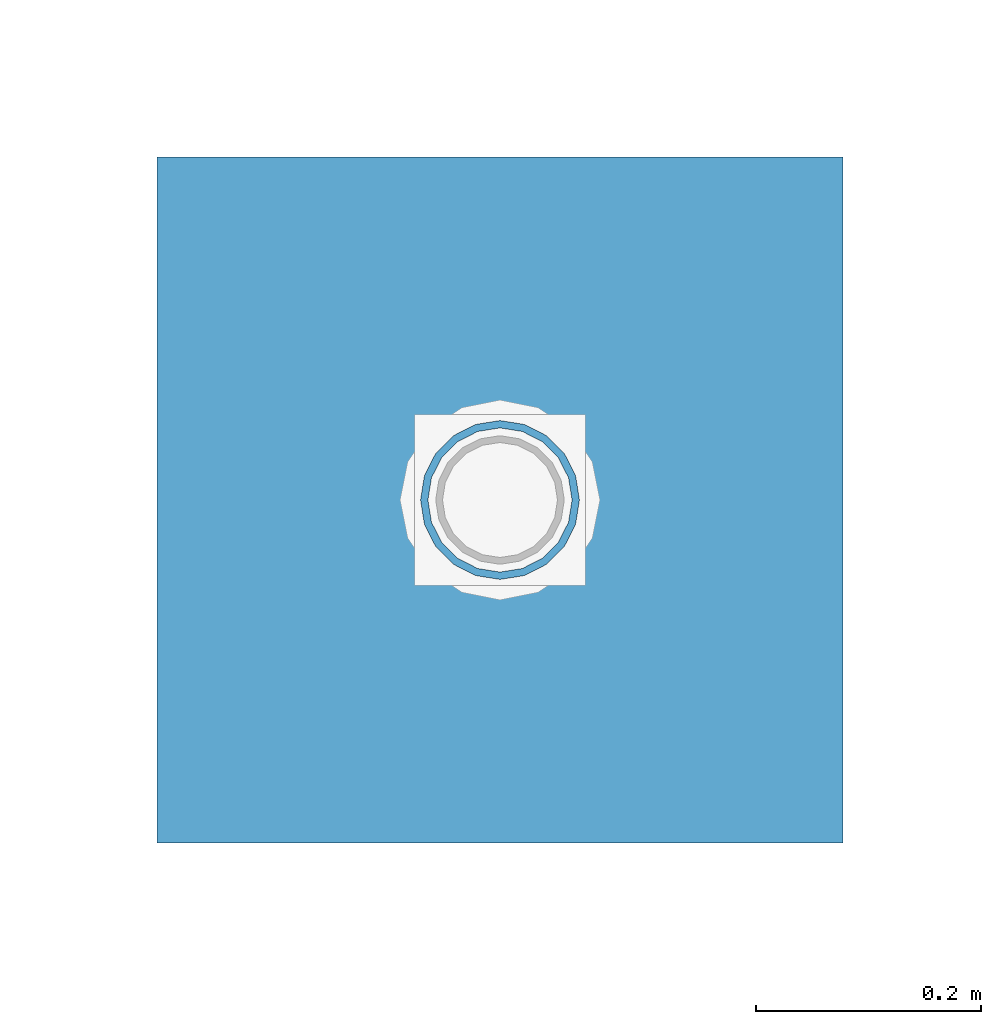
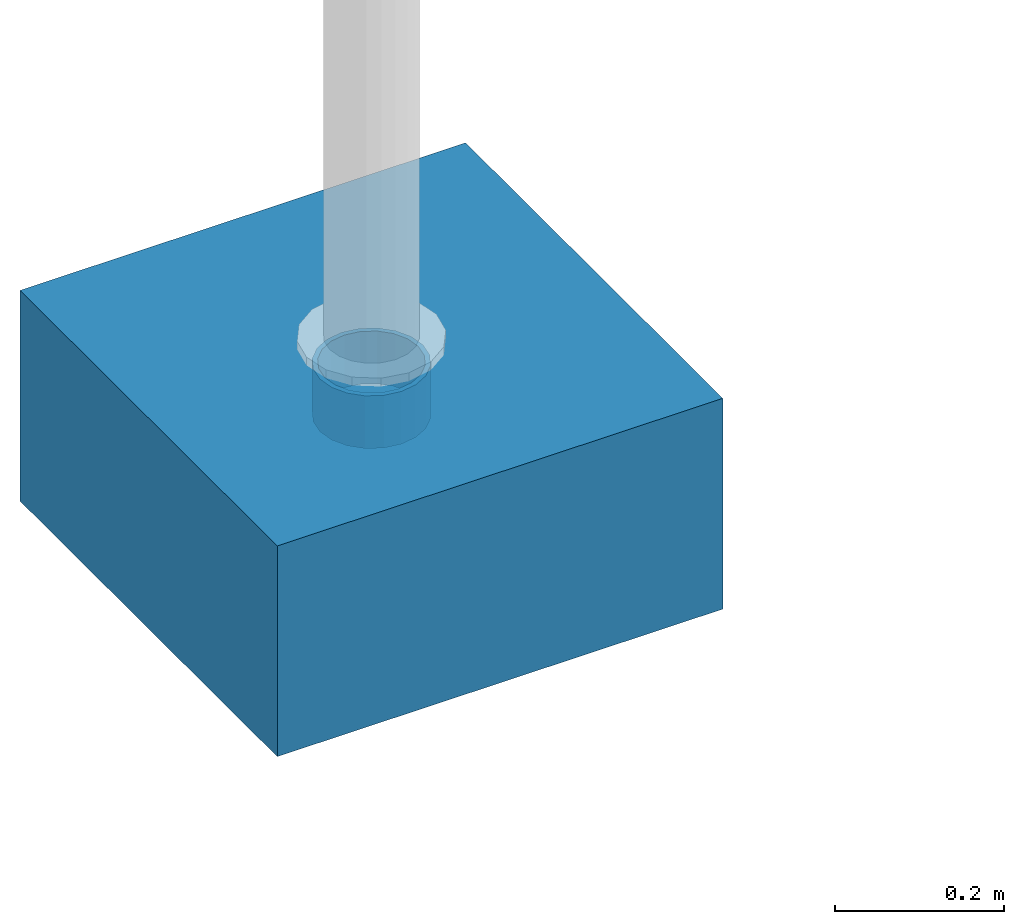
# One storey, part 1532 of 3843: 2 columns, 2 elements without a shape of their own.
"""IFC2X3 building model written with IfcOpenShell, lengths in millimetres."""

from ifc_helpers import new_model, si_unit, frame, origin_with_axes, place, context, subcontext, project, spatial, faceted_brep, material, type_object, element, aggregate, save


model = new_model("IFC2X3")

# Units and contexts
model_context = context("Model", 3, precision=1e-05, world=origin_with_axes())
body_context = subcontext(model_context, "Body", "Model", "MODEL_VIEW")
ifc_project = project(units=[si_unit("LENGTHUNIT", "METRE", prefix="MILLI"), si_unit("AREAUNIT", "SQUARE_METRE"), si_unit("VOLUMEUNIT", "CUBIC_METRE"), si_unit("MASSUNIT", "GRAM", prefix="KILO"), si_unit("TIMEUNIT", "SECOND"), si_unit("PLANEANGLEUNIT", "RADIAN"), si_unit("SOLIDANGLEUNIT", "STERADIAN"), si_unit("THERMODYNAMICTEMPERATUREUNIT", "DEGREE_CELSIUS"), si_unit("LUMINOUSINTENSITYUNIT", "LUMEN")], contexts=[model_context])

# Site, building, storey
site_placement = place(None, origin_with_axes())
site = spatial("IfcSite", under=ifc_project, at=site_placement, CompositionType="ELEMENT")
building_placement = place(site_placement, origin_with_axes())
building = spatial("IfcBuilding", under=site, at=building_placement, Name="Undefined", CompositionType="ELEMENT")
storey_placement = place(building_placement, origin_with_axes())
storey = spatial("IfcBuildingStorey", under=building, at=storey_placement, Name="Undefined", CompositionType="ELEMENT", Elevation=0.0)

# Assembly, column
assembly_1_placement = place(storey_placement, origin_with_axes())
assembly_1 = element("IfcElementAssembly", 1, at=assembly_1_placement, inside=storey, Name="PLATE", AssemblyPlace="NOTDEFINED", PredefinedType="RIGID_FRAME")
ifc_material_1 = material()
column_type_1 = type_object("IfcColumnType", Name="PIPE5SCH40", PredefinedType="NOTDEFINED")
column_1_placement = place(assembly_1_placement, frame((-31322.367188, 75641.398438, 30378.4), z_axis=(-1.0, 0.0, 0.0), x_axis=(0.0, 0.0, 1.0)))
column_1 = element("IfcColumn", 2, at=column_1_placement, type_object=column_type_1, material=ifc_material_1, Name="PIPE_SLEEVE", ObjectType="PIPE5SCH40", context=body_context, shape_type="Brep", body=[
    faceted_brep([(0.0, -64.0587999999998, 0.0), (0.0, -60.9235391660477, 19.7952578392724), (76.2000000000007, -60.9235391660477, 19.7952578392724), (76.2000000000007, -64.0587999999998, 0.0), (0.0, -51.8246578392655, 37.6528179195593), (76.2000000000007, -51.8246578392655, 37.6528179195593), (0.0, -37.6528179195529, 51.8246578392718), (76.2000000000007, -37.6528179195529, 51.8246578392718), (0.0, -19.795257839266, 60.9235391660477), (76.2000000000007, -19.795257839266, 60.9235391660477), (0.0, 0.0, 64.0587999999989), (76.2000000000007, 0.0, 64.0587999999989), (0.0, 19.795257839266, 60.9235391660477), (76.2000000000007, 19.795257839266, 60.9235391660477), (0.0, 37.6528179195529, 51.8246578392718), (76.2000000000007, 37.6528179195529, 51.8246578392718), (0.0, 51.8246578392655, 37.6528179195593), (76.2000000000007, 51.8246578392655, 37.6528179195593), (0.0, 60.9235391660477, 19.7952578392724), (76.2000000000007, 60.9235391660477, 19.7952578392724), (0.0, 64.0587999999998, 0.0), (76.2000000000007, 64.0587999999998, 0.0), (0.0, 60.9235391660477, -19.7952578392724), (76.2000000000007, 60.9235391660477, -19.7952578392724), (0.0, 51.8246578392655, -37.6528179195593), (76.2000000000007, 51.8246578392655, -37.6528179195593), (0.0, 37.6528179195529, -51.8246578392718), (76.2000000000007, 37.6528179195529, -51.8246578392718), (0.0, 19.795257839266, -60.9235391660477), (76.2000000000007, 19.795257839266, -60.9235391660477), (0.0, 0.0, -64.0587999999989), (76.2000000000007, 0.0, -64.0587999999989), (0.0, -19.795257839266, -60.9235391660477), (76.2000000000007, -19.795257839266, -60.9235391660477), (0.0, -37.6528179195529, -51.8246578392718), (76.2000000000007, -37.6528179195529, -51.8246578392718), (0.0, -51.8246578392655, -37.6528179195593), (76.2000000000007, -51.8246578392655, -37.6528179195593), (0.0, -60.9235391660477, -19.7952578392724), (76.2000000000007, -60.9235391660477, -19.7952578392724), (0.0, -70.6120000000001, 0.0), (0.0, -67.1560027286332, -21.8203080068051), (76.2000000000007, -67.1560027286332, -21.8203080068051), (76.2000000000007, -70.6120000000001, 0.0), (0.0, -57.1263080068038, -41.5046922348702), (76.2000000000007, -57.1263080068038, -41.5046922348702), (0.0, -41.5046922348765, -57.126308006802), (76.2000000000007, -41.5046922348765, -57.126308006802), (0.0, -21.8203080068042, -67.1560027286323), (76.2000000000007, -21.8203080068042, -67.1560027286323), (0.0, 0.0, -70.6119999999937), (76.2000000000007, 0.0, -70.6119999999937), (0.0, 21.8203080068042, -67.1560027286323), (76.2000000000007, 21.8203080068042, -67.1560027286323), (0.0, 41.5046922348765, -57.126308006802), (76.2000000000007, 41.5046922348765, -57.126308006802), (0.0, 57.1263080068038, -41.5046922348702), (76.2000000000007, 57.1263080068038, -41.5046922348702), (0.0, 67.1560027286332, -21.8203080068051), (76.2000000000007, 67.1560027286332, -21.8203080068051), (0.0, 70.6120000000001, 0.0), (76.2000000000007, 70.6120000000001, 0.0), (0.0, 67.1560027286332, 21.8203080068051), (76.2000000000007, 67.1560027286332, 21.8203080068051), (0.0, 57.1263080068038, 41.5046922348702), (76.2000000000007, 57.1263080068038, 41.5046922348702), (0.0, 41.5046922348765, 57.126308006802), (76.2000000000007, 41.5046922348765, 57.126308006802), (0.0, 21.8203080068042, 67.1560027286323), (76.2000000000007, 21.8203080068042, 67.1560027286323), (0.0, 0.0, 70.6119999999937), (76.2000000000007, 0.0, 70.6119999999937), (0.0, -21.8203080068042, 67.1560027286323), (76.2000000000007, -21.8203080068042, 67.1560027286323), (0.0, -41.5046922348765, 57.126308006802), (76.2000000000007, -41.5046922348765, 57.126308006802), (0.0, -57.1263080068038, 41.5046922348702), (76.2000000000007, -57.1263080068038, 41.5046922348702), (0.0, -67.1560027286332, 21.8203080068051), (76.2000000000007, -67.1560027286332, 21.8203080068051)], [[[0, 1, 2, 3]], [[1, 4, 5, 2]], [[4, 6, 7, 5]], [[6, 8, 9, 7]], [[8, 10, 11, 9]], [[10, 12, 13, 11]], [[12, 14, 15, 13]], [[14, 16, 17, 15]], [[16, 18, 19, 17]], [[18, 20, 21, 19]], [[20, 22, 23, 21]], [[22, 24, 25, 23]], [[24, 26, 27, 25]], [[26, 28, 29, 27]], [[28, 30, 31, 29]], [[30, 32, 33, 31]], [[32, 34, 35, 33]], [[34, 36, 37, 35]], [[36, 38, 39, 37]], [[38, 0, 3, 39]], [[40, 41, 42, 43]], [[41, 44, 45, 42]], [[44, 46, 47, 45]], [[46, 48, 49, 47]], [[48, 50, 51, 49]], [[50, 52, 53, 51]], [[52, 54, 55, 53]], [[54, 56, 57, 55]], [[56, 58, 59, 57]], [[58, 60, 61, 59]], [[60, 62, 63, 61]], [[62, 64, 65, 63]], [[64, 66, 67, 65]], [[66, 68, 69, 67]], [[68, 70, 71, 69]], [[70, 72, 73, 71]], [[72, 74, 75, 73]], [[74, 76, 77, 75]], [[76, 78, 79, 77]], [[78, 40, 43, 79]], [[45, 47, 49, 51, 53, 55, 57, 59, 61, 63, 65, 67, 69, 71, 73, 75, 77, 79, 43, 42], [5, 7, 9, 11, 13, 15, 17, 19, 21, 23, 25, 27, 29, 31, 33, 35, 37, 39, 3, 2]], [[78, 76, 74, 72, 70, 68, 66, 64, 62, 60, 58, 56, 54, 52, 50, 48, 46, 44, 41, 40], [38, 36, 34, 32, 30, 28, 26, 24, 22, 20, 18, 16, 14, 12, 10, 8, 6, 4, 1, 0]]]),
])
aggregate(assembly_1, [column_1])

assembly_2_placement = place(storey_placement, origin_with_axes())
assembly_2 = element("IfcElementAssembly", 3, at=assembly_2_placement, inside=storey, Name="CONC_COL.", AssemblyPlace="NOTDEFINED", PredefinedType="REINFORCEMENT_UNIT")
ifc_material_2 = material(Name="CONCRETE/3000")
column_type_2 = type_object("IfcColumnType", PredefinedType="NOTDEFINED")
column_2_placement = place(assembly_2_placement, frame((-31322.367188, 75641.398438, 30175.2), z_axis=(-1.0, 0.0, 0.0), x_axis=(0.0, 0.0, 1.0)))
column_2 = element("IfcColumn", 4, at=column_2_placement, type_object=column_type_2, material=ifc_material_2, Name="CONC_COL.", context=body_context, shape_type="Brep", body=[
    faceted_brep([(0.0, 304.8, -304.800000000003), (0.0, 304.8, 304.800000000003), (304.799999999999, 304.8, 304.800000000003), (304.799999999999, 304.8, -304.800000000003), (0.0, -304.8, 304.800000000003), (304.799999999999, -304.8, 304.800000000003), (0.0, -304.8, -304.800000000003), (304.799999999999, -304.8, -304.800000000003)], [[[0, 1, 2, 3]], [[1, 4, 5, 2]], [[4, 6, 7, 5]], [[6, 0, 3, 7]], [[5, 7, 3, 2]], [[6, 4, 1, 0]]]),
])
aggregate(assembly_2, [column_2])

save(model, "model.ifc")
